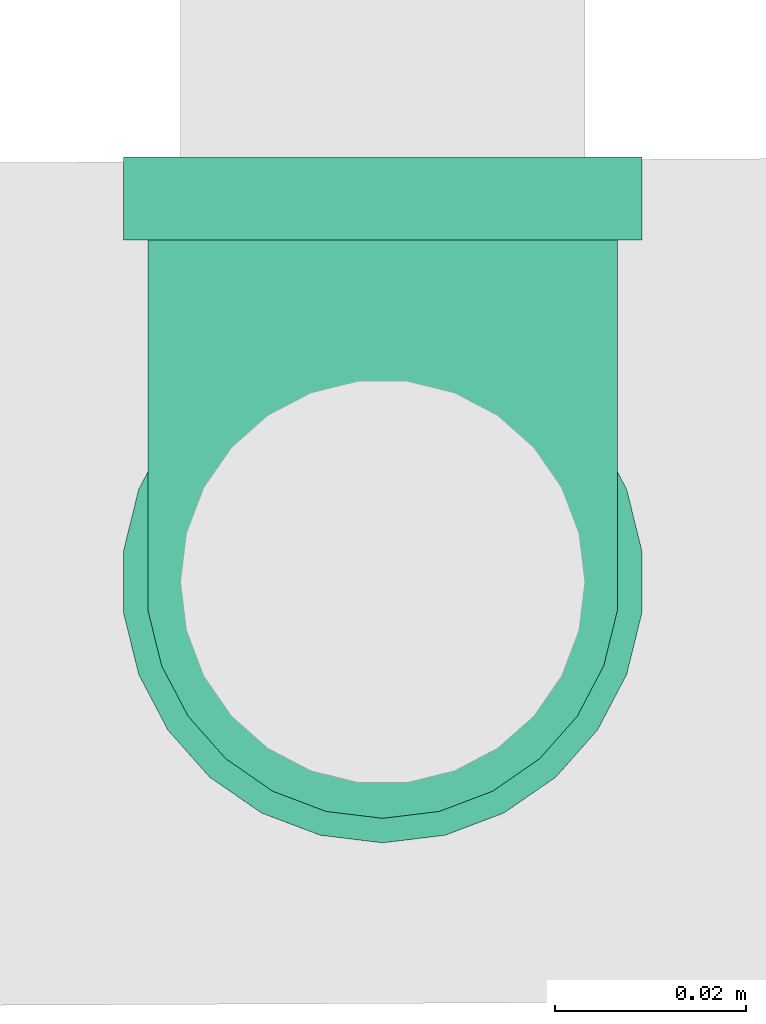
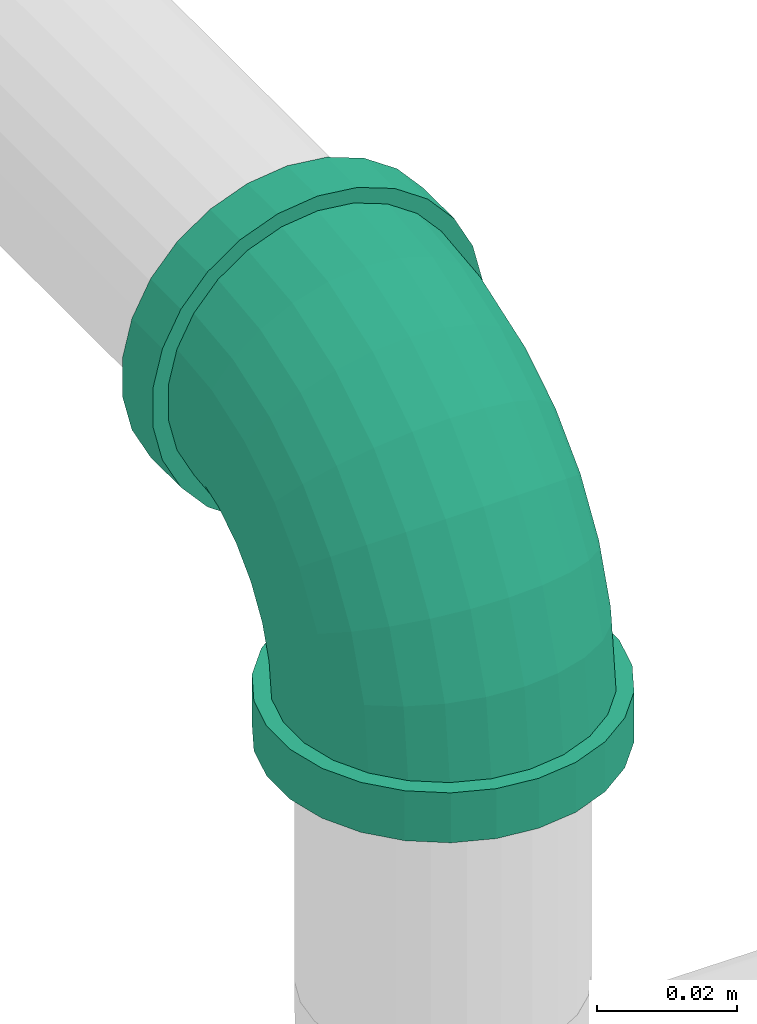
# One storey, part 3 of 7: 1 pipe fitting.
"""IFC4 building model written with IfcOpenShell, lengths in millimetres."""

from ifc_helpers import new_model, entity, si_unit, converted_unit, derived_unit, direction, frame, origin, place, context, subcontext, project, spatial, source, transform, mapped, type_object, type_shapes, element, save


model = new_model("IFC4")

# Units and contexts
model_context = context("Model", 3, precision=0.01, world=origin(), true_north=direction((6.12303176911189e-17, 1.0)))
body_context = subcontext(model_context, "Body", "Model", "MODEL_VIEW")
ifc_project = project(units=[si_unit("LENGTHUNIT", "METRE", prefix="MILLI"), si_unit("AREAUNIT", "SQUARE_METRE"), si_unit("VOLUMEUNIT", "CUBIC_METRE"), converted_unit("PLANEANGLEUNIT", "DEGREE", entity("IfcRatioMeasure", 0.0174532925199433), si_unit("PLANEANGLEUNIT", "RADIAN"), dimensions=[0, 0, 0, 0, 0, 0, 0]), si_unit("MASSUNIT", "GRAM", prefix="KILO"), derived_unit("MASSDENSITYUNIT", [(si_unit("MASSUNIT", "GRAM", prefix="KILO"), 1), (si_unit("LENGTHUNIT", "METRE"), -3)]), derived_unit("MOMENTOFINERTIAUNIT", [(si_unit("LENGTHUNIT", "METRE"), 4)]), si_unit("TIMEUNIT", "SECOND"), si_unit("FREQUENCYUNIT", "HERTZ"), si_unit("THERMODYNAMICTEMPERATUREUNIT", "DEGREE_CELSIUS"), derived_unit("THERMALTRANSMITTANCEUNIT", [(si_unit("MASSUNIT", "GRAM", prefix="KILO"), 1), (si_unit("THERMODYNAMICTEMPERATUREUNIT", "KELVIN"), -1), (si_unit("TIMEUNIT", "SECOND"), -3)]), derived_unit("VOLUMETRICFLOWRATEUNIT", [(si_unit("LENGTHUNIT", "METRE"), 3), (si_unit("TIMEUNIT", "SECOND"), -1)]), si_unit("ELECTRICCURRENTUNIT", "AMPERE"), si_unit("ELECTRICVOLTAGEUNIT", "VOLT"), si_unit("POWERUNIT", "WATT"), si_unit("FORCEUNIT", "NEWTON", prefix="KILO"), si_unit("ILLUMINANCEUNIT", "LUX"), si_unit("LUMINOUSFLUXUNIT", "LUMEN"), si_unit("LUMINOUSINTENSITYUNIT", "CANDELA"), derived_unit("USERDEFINED", [(si_unit("MASSUNIT", "GRAM", prefix="KILO"), -1), (si_unit("LENGTHUNIT", "METRE"), -2), (si_unit("TIMEUNIT", "SECOND"), 3), (si_unit("LUMINOUSFLUXUNIT", "LUMEN"), 1)]), derived_unit("LINEARVELOCITYUNIT", [(si_unit("LENGTHUNIT", "METRE"), 1), (si_unit("TIMEUNIT", "SECOND"), -1)]), si_unit("PRESSUREUNIT", "PASCAL"), derived_unit("USERDEFINED", [(si_unit("LENGTHUNIT", "METRE"), -2), (si_unit("MASSUNIT", "GRAM", prefix="KILO"), 1), (si_unit("TIMEUNIT", "SECOND"), -2)]), derived_unit("LINEARFORCEUNIT", [(si_unit("MASSUNIT", "GRAM", prefix="KILO"), 1), (si_unit("LENGTHUNIT", "METRE"), 1), (si_unit("TIMEUNIT", "SECOND"), -2), (si_unit("LENGTHUNIT", "METRE"), -1)]), derived_unit("PLANARFORCEUNIT", [(si_unit("MASSUNIT", "GRAM", prefix="KILO"), 1), (si_unit("LENGTHUNIT", "METRE"), 1), (si_unit("TIMEUNIT", "SECOND"), -2), (si_unit("LENGTHUNIT", "METRE"), -2)])], contexts=[model_context])

# Site, building, storey
site_placement = place(None, origin())
site = spatial("IfcSite", under=ifc_project, at=site_placement, CompositionType="ELEMENT")
building_placement = place(site_placement, origin())
building = spatial("IfcBuilding", under=site, at=building_placement, CompositionType="ELEMENT")
storey_placement = place(building_placement, origin())
storey = spatial("IfcBuildingStorey", under=building, at=storey_placement, Name="Ebene 1", CompositionType="ELEMENT", Elevation=0.0)

# Pipe fitting
pipe_fitting_type = type_object("IfcPipeFittingType", Name="Threaded - Elbow - MI - Class 1:Standard 4", PredefinedType="NOTDEFINED")
cartesian_point_1 = entity("IfcCartesianPoint", [-44.4999999999936, -27.3500000000084, 0.0])
vertex_point_1 = entity("IfcVertexPoint", cartesian_point_1)
cartesian_point_2 = entity("IfcCartesianPoint", [-44.4999999999936, 27.3499999999916, 0.0])
vertex_point_2 = entity("IfcVertexPoint", cartesian_point_2)
cartesian_point_3 = entity("IfcCartesianPoint", [-44.4999999999936, 0.0, 0.0])
ifc_direction_1 = entity("IfcDirection", [-1.0, 0.0, 0.0])
ifc_direction_2 = entity("IfcDirection", [0.0, 1.0, 0.0])
edge_curve_1 = entity("IfcEdgeCurve", vertex_point_1, vertex_point_2, entity("IfcTrimmedCurve", entity("IfcCircle", entity("IfcAxis2Placement3D", cartesian_point_3, ifc_direction_1, ifc_direction_2), 27.35), [cartesian_point_1], [cartesian_point_2], True, "CARTESIAN"), True)
edge_curve_2 = entity("IfcEdgeCurve", vertex_point_2, vertex_point_1, entity("IfcTrimmedCurve", entity("IfcCircle", entity("IfcAxis2Placement3D", cartesian_point_3, ifc_direction_1, ifc_direction_2), 27.35), [cartesian_point_2], [cartesian_point_1], True, "CARTESIAN"), True)
cartesian_point_4 = entity("IfcCartesianPoint", [-44.4999999999936, 21.0819999999918, 0.0])
vertex_point_3 = entity("IfcVertexPoint", cartesian_point_4)
cartesian_point_5 = entity("IfcCartesianPoint", [-44.4999999999936, -21.0820000000082, 0.0])
vertex_point_4 = entity("IfcVertexPoint", cartesian_point_5)
ifc_direction_3 = entity("IfcDirection", [1.0, 0.0, 0.0])
edge_curve_3 = entity("IfcEdgeCurve", vertex_point_3, vertex_point_4, entity("IfcTrimmedCurve", entity("IfcCircle", entity("IfcAxis2Placement3D", cartesian_point_3, ifc_direction_3, ifc_direction_2), 21.082), [cartesian_point_4], [cartesian_point_5], True, "CARTESIAN"), True)
edge_curve_4 = entity("IfcEdgeCurve", vertex_point_4, vertex_point_3, entity("IfcTrimmedCurve", entity("IfcCircle", entity("IfcAxis2Placement3D", cartesian_point_3, ifc_direction_3, ifc_direction_2), 21.082), [cartesian_point_5], [cartesian_point_4], True, "CARTESIAN"), True)
ifc_direction_4 = entity("IfcDirection", [0.0, 0.0, 1.0])
cartesian_point_6 = entity("IfcCartesianPoint", [-35.7999999999934, 27.3499999999916, 0.0])
vertex_point_5 = entity("IfcVertexPoint", cartesian_point_6)
cartesian_point_7 = entity("IfcCartesianPoint", [-35.7999999999934, -27.3500000000084, 0.0])
vertex_point_6 = entity("IfcVertexPoint", cartesian_point_7)
cartesian_point_8 = entity("IfcCartesianPoint", [-35.7999999999934, 0.0, 0.0])
edge_curve_5 = entity("IfcEdgeCurve", vertex_point_5, vertex_point_6, entity("IfcTrimmedCurve", entity("IfcCircle", entity("IfcAxis2Placement3D", cartesian_point_8, ifc_direction_3, ifc_direction_2), 27.35), [cartesian_point_6], [cartesian_point_7], True, "CARTESIAN"), True)
edge_curve_6 = entity("IfcEdgeCurve", vertex_point_6, vertex_point_5, entity("IfcTrimmedCurve", entity("IfcCircle", entity("IfcAxis2Placement3D", cartesian_point_8, ifc_direction_3, ifc_direction_2), 27.35), [cartesian_point_7], [cartesian_point_6], True, "CARTESIAN"), True)
cartesian_point_9 = entity("IfcCartesianPoint", [-35.7999999999934, -24.7800000000084, 0.0])
vertex_point_7 = entity("IfcVertexPoint", cartesian_point_9)
cartesian_point_10 = entity("IfcCartesianPoint", [-35.7999999999934, 24.7799999999916, 0.0])
vertex_point_8 = entity("IfcVertexPoint", cartesian_point_10)
edge_curve_7 = entity("IfcEdgeCurve", vertex_point_7, vertex_point_8, entity("IfcTrimmedCurve", entity("IfcCircle", entity("IfcAxis2Placement3D", cartesian_point_8, ifc_direction_1, ifc_direction_2), 24.78), [cartesian_point_9], [cartesian_point_10], True, "CARTESIAN"), True)
edge_curve_8 = entity("IfcEdgeCurve", vertex_point_8, vertex_point_7, entity("IfcTrimmedCurve", entity("IfcCircle", entity("IfcAxis2Placement3D", cartesian_point_8, ifc_direction_1, ifc_direction_2), 24.78), [cartesian_point_10], [cartesian_point_9], True, "CARTESIAN"), True)
edge_curve_9 = entity("IfcEdgeCurve", vertex_point_1, vertex_point_6, entity("IfcTrimmedCurve", entity("IfcLine", cartesian_point_1, entity("IfcVector", ifc_direction_3, 304.8)), [cartesian_point_1], [cartesian_point_7], True, "CARTESIAN"), True)
edge_curve_10 = entity("IfcEdgeCurve", vertex_point_5, vertex_point_2, entity("IfcTrimmedCurve", entity("IfcLine", cartesian_point_2, entity("IfcVector", ifc_direction_1, 304.8)), [cartesian_point_6], [cartesian_point_2], True, "CARTESIAN"), True)
cartesian_point_11 = entity("IfcCartesianPoint", [-35.7999999999935, 21.0819999999918, 0.0])
vertex_point_9 = entity("IfcVertexPoint", cartesian_point_11)
edge_curve_11 = entity("IfcEdgeCurve", vertex_point_3, vertex_point_9, entity("IfcTrimmedCurve", entity("IfcLine", cartesian_point_11, entity("IfcVector", ifc_direction_3, 304.8)), [cartesian_point_4], [cartesian_point_11], True, "CARTESIAN"), True)
cartesian_point_12 = entity("IfcCartesianPoint", [-35.7999999999934, -21.0820000000082, 0.0])
vertex_point_10 = entity("IfcVertexPoint", cartesian_point_12)
edge_curve_12 = entity("IfcEdgeCurve", vertex_point_9, vertex_point_10, entity("IfcTrimmedCurve", entity("IfcCircle", entity("IfcAxis2Placement3D", cartesian_point_8, ifc_direction_3, ifc_direction_2), 21.082), [cartesian_point_11], [cartesian_point_12], True, "CARTESIAN"), True)
edge_curve_13 = entity("IfcEdgeCurve", vertex_point_10, vertex_point_4, entity("IfcTrimmedCurve", entity("IfcLine", cartesian_point_12, entity("IfcVector", ifc_direction_1, 304.8)), [cartesian_point_12], [cartesian_point_5], True, "CARTESIAN"), True)
cartesian_point_13 = entity("IfcCartesianPoint", [-27.0374999999917, 0.0, 0.0])
edge_curve_14 = entity("IfcEdgeCurve", vertex_point_10, vertex_point_9, entity("IfcTrimmedCurve", entity("IfcCircle", entity("IfcAxis2Placement3D", cartesian_point_8, ifc_direction_3, ifc_direction_2), 21.082), [cartesian_point_12], [cartesian_point_11], True, "CARTESIAN"), True)
cartesian_point_14 = entity("IfcCartesianPoint", [27.3598993756537, 35.7924350408555, 0.0])
vertex_point_11 = entity("IfcVertexPoint", cartesian_point_14)
cartesian_point_15 = entity("IfcCartesianPoint", [-27.3400985326499, 35.8075622211851, 0.0])
vertex_point_12 = entity("IfcVertexPoint", cartesian_point_15)
cartesian_point_16 = entity("IfcCartesianPoint", [0.00990042150192459, 35.7999986310203, 0.0])
edge_curve_15 = entity("IfcEdgeCurve", vertex_point_11, vertex_point_12, entity("IfcTrimmedCurve", entity("IfcCircle", entity("IfcAxis2Placement3D", cartesian_point_16, entity("IfcDirection", [-0.000276548086464422, -0.999999961760577, 0.0]), entity("IfcDirection", [-0.999999961760577, 0.000276548086464422, 0.0])), 27.35), [cartesian_point_14], [cartesian_point_15], True, "CARTESIAN"), True)
edge_curve_16 = entity("IfcEdgeCurve", vertex_point_12, vertex_point_11, entity("IfcTrimmedCurve", entity("IfcCircle", entity("IfcAxis2Placement3D", cartesian_point_16, entity("IfcDirection", [-0.000276548086464422, -0.999999961760577, 0.0]), entity("IfcDirection", [-0.999999961760577, 0.000276548086464422, 0.0])), 27.35), [cartesian_point_15], [cartesian_point_14], True, "CARTESIAN"), True)
cartesian_point_17 = entity("IfcCartesianPoint", [-24.7700986309252, 35.8068514926029, 0.0])
vertex_point_13 = entity("IfcVertexPoint", cartesian_point_17)
cartesian_point_18 = entity("IfcCartesianPoint", [24.789899473929, 35.7931457694377, 0.0])
vertex_point_14 = entity("IfcVertexPoint", cartesian_point_18)
edge_curve_17 = entity("IfcEdgeCurve", vertex_point_13, vertex_point_14, entity("IfcTrimmedCurve", entity("IfcCircle", entity("IfcAxis2Placement3D", cartesian_point_16, entity("IfcDirection", [0.000276548086462547, 0.999999961760577, 0.0]), entity("IfcDirection", [-0.999999961760577, 0.000276548086462547, 0.0])), 24.78), [cartesian_point_17], [cartesian_point_18], True, "CARTESIAN"), True)
edge_curve_18 = entity("IfcEdgeCurve", vertex_point_14, vertex_point_13, entity("IfcTrimmedCurve", entity("IfcCircle", entity("IfcAxis2Placement3D", cartesian_point_16, entity("IfcDirection", [0.000276548086462547, 0.999999961760577, 0.0]), entity("IfcDirection", [-0.999999961760577, 0.000276548086462547, 0.0])), 24.78), [cartesian_point_18], [cartesian_point_17], True, "CARTESIAN"), True)
cartesian_point_19 = entity("IfcCartesianPoint", [-27.3376925642976, 44.5075618885021, 0.0])
vertex_point_15 = entity("IfcVertexPoint", cartesian_point_19)
cartesian_point_20 = entity("IfcCartesianPoint", [27.362305344006, 44.4924347081725, 0.0])
vertex_point_16 = entity("IfcVertexPoint", cartesian_point_20)
cartesian_point_21 = entity("IfcCartesianPoint", [0.0123063898541651, 44.4999982983373, 0.0])
edge_curve_19 = entity("IfcEdgeCurve", vertex_point_15, vertex_point_16, entity("IfcTrimmedCurve", entity("IfcCircle", entity("IfcAxis2Placement3D", cartesian_point_21, entity("IfcDirection", [0.000276548086464422, 0.999999961760577, 0.0]), entity("IfcDirection", [-0.999999961760577, 0.000276548086464422, 0.0])), 27.35), [cartesian_point_19], [cartesian_point_20], True, "CARTESIAN"), True)
edge_curve_20 = entity("IfcEdgeCurve", vertex_point_16, vertex_point_15, entity("IfcTrimmedCurve", entity("IfcCircle", entity("IfcAxis2Placement3D", cartesian_point_21, entity("IfcDirection", [0.000276548086464422, 0.999999961760577, 0.0]), entity("IfcDirection", [-0.999999961760577, 0.000276548086464422, 0.0])), 27.35), [cartesian_point_20], [cartesian_point_19], True, "CARTESIAN"), True)
cartesian_point_22 = entity("IfcCartesianPoint", [0.0123063898201877, 44.4999982983373, -21.081999999986])
vertex_point_17 = entity("IfcVertexPoint", cartesian_point_22)
cartesian_point_23 = entity("IfcCartesianPoint", [0.0123063898199927, 44.4999982983373, 21.082000000014])
vertex_point_18 = entity("IfcVertexPoint", cartesian_point_23)
ifc_direction_5 = entity("IfcDirection", [0.0, 0.0, -1.0])
edge_curve_21 = entity("IfcEdgeCurve", vertex_point_17, vertex_point_18, entity("IfcTrimmedCurve", entity("IfcCircle", entity("IfcAxis2Placement3D", cartesian_point_21, entity("IfcDirection", [-0.000276548086464422, -0.999999961760577, 0.0]), ifc_direction_5), 21.082), [cartesian_point_22], [cartesian_point_23], True, "CARTESIAN"), True)
edge_curve_22 = entity("IfcEdgeCurve", vertex_point_18, vertex_point_17, entity("IfcTrimmedCurve", entity("IfcCircle", entity("IfcAxis2Placement3D", cartesian_point_21, entity("IfcDirection", [-0.000276548086464422, -0.999999961760577, 0.0]), ifc_direction_5), 21.082), [cartesian_point_23], [cartesian_point_22], True, "CARTESIAN"), True)
edge_curve_23 = entity("IfcEdgeCurve", vertex_point_11, vertex_point_16, entity("IfcTrimmedCurve", entity("IfcLine", cartesian_point_14, entity("IfcVector", entity("IfcDirection", [0.000276548086464574, 0.999999961760577, 0.0]), 304.8)), [cartesian_point_14], [cartesian_point_20], True, "CARTESIAN"), True)
edge_curve_24 = entity("IfcEdgeCurve", vertex_point_15, vertex_point_12, entity("IfcTrimmedCurve", entity("IfcLine", cartesian_point_15, entity("IfcVector", entity("IfcDirection", [-0.000276548086464574, -0.999999961760577, 0.0]), 304.8)), [cartesian_point_19], [cartesian_point_15], True, "CARTESIAN"), True)
cartesian_point_24 = entity("IfcCartesianPoint", [0.00990042146834042, 35.7999986310203, -21.081999999986])
vertex_point_19 = entity("IfcVertexPoint", cartesian_point_24)
edge_curve_25 = entity("IfcEdgeCurve", vertex_point_17, vertex_point_19, entity("IfcTrimmedCurve", entity("IfcLine", cartesian_point_24, entity("IfcVector", entity("IfcDirection", [-0.000276548086464422, -0.999999961760577, 0.0]), 304.8)), [cartesian_point_22], [cartesian_point_24], True, "CARTESIAN"), True)
cartesian_point_25 = entity("IfcCartesianPoint", [0.00990042146775222, 35.7999986310203, 21.082000000014])
vertex_point_20 = entity("IfcVertexPoint", cartesian_point_25)
edge_curve_26 = entity("IfcEdgeCurve", vertex_point_19, vertex_point_20, entity("IfcTrimmedCurve", entity("IfcCircle", entity("IfcAxis2Placement3D", cartesian_point_16, entity("IfcDirection", [-0.000276548086464422, -0.999999961760577, 0.0]), ifc_direction_5), 21.082), [cartesian_point_24], [cartesian_point_25], True, "CARTESIAN"), True)
edge_curve_27 = entity("IfcEdgeCurve", vertex_point_20, vertex_point_18, entity("IfcTrimmedCurve", entity("IfcLine", cartesian_point_25, entity("IfcVector", entity("IfcDirection", [0.000276548086464422, 0.999999961760577, 0.0]), 304.8)), [cartesian_point_25], [cartesian_point_23], True, "CARTESIAN"), True)
cartesian_point_26 = entity("IfcCartesianPoint", [0.00747716886016596, 27.0374989660914, 0.0])
edge_curve_28 = entity("IfcEdgeCurve", vertex_point_20, vertex_point_19, entity("IfcTrimmedCurve", entity("IfcCircle", entity("IfcAxis2Placement3D", cartesian_point_16, entity("IfcDirection", [-0.000276548086464422, -0.999999961760577, 0.0]), ifc_direction_5), 21.082), [cartesian_point_25], [cartesian_point_24], True, "CARTESIAN"), True)
cartesian_point_27 = entity("IfcCartesianPoint", [-35.7999999999935, 35.809901790837, 0.0])
ifc_direction_6 = entity("IfcDirection", [0.0, -1.0, 0.0])
edge_curve_29 = entity("IfcEdgeCurve", vertex_point_13, vertex_point_8, entity("IfcTrimmedCurve", entity("IfcCircle", entity("IfcAxis2Placement3D", cartesian_point_27, ifc_direction_5, ifc_direction_6), 11.0299017908454), [cartesian_point_17], [cartesian_point_10], True, "CARTESIAN"), True)
edge_curve_30 = entity("IfcEdgeCurve", vertex_point_7, vertex_point_14, entity("IfcTrimmedCurve", entity("IfcCircle", entity("IfcAxis2Placement3D", cartesian_point_27, ifc_direction_4, ifc_direction_6), 60.5899017908454), [cartesian_point_9], [cartesian_point_18], True, "CARTESIAN"), True)
cartesian_point_28 = entity("IfcCartesianPoint", [0.00990179085189292, 35.809901790837, 0.0])
cartesian_point_29 = entity("IfcCartesianPoint", [24.7899017908519, 35.809901790837, 0.0])
cartesian_point_30 = entity("IfcCartesianPoint", [-24.7700982091481, 35.809901790837, 0.0])
shared_shape = source(origin(), body_context, "Body", "AdvancedBrep", [
    entity("IfcAdvancedBrep", entity("IfcClosedShell", [entity("IfcAdvancedFace", [entity("IfcFaceOuterBound", entity("IfcEdgeLoop", [entity("IfcOrientedEdge", None, None, edge_curve_1, True), entity("IfcOrientedEdge", None, None, edge_curve_2, True)]), True), entity("IfcFaceBound", entity("IfcEdgeLoop", [entity("IfcOrientedEdge", None, None, edge_curve_3, True), entity("IfcOrientedEdge", None, None, edge_curve_4, True)]), False)], entity("IfcPlane", entity("IfcAxis2Placement3D", cartesian_point_3, ifc_direction_1, ifc_direction_4)), True), entity("IfcAdvancedFace", [entity("IfcFaceOuterBound", entity("IfcEdgeLoop", [entity("IfcOrientedEdge", None, None, edge_curve_5, True), entity("IfcOrientedEdge", None, None, edge_curve_6, True)]), True), entity("IfcFaceBound", entity("IfcEdgeLoop", [entity("IfcOrientedEdge", None, None, edge_curve_7, True), entity("IfcOrientedEdge", None, None, edge_curve_8, True)]), False)], entity("IfcPlane", entity("IfcAxis2Placement3D", cartesian_point_8, ifc_direction_3, ifc_direction_4)), True), entity("IfcAdvancedFace", [entity("IfcFaceOuterBound", entity("IfcEdgeLoop", [entity("IfcOrientedEdge", None, None, edge_curve_1, False), entity("IfcOrientedEdge", None, None, edge_curve_9, True), entity("IfcOrientedEdge", None, None, edge_curve_5, False), entity("IfcOrientedEdge", None, None, edge_curve_10, True)]), True)], entity("IfcCylindricalSurface", entity("IfcAxis2Placement3D", cartesian_point_3, ifc_direction_1, ifc_direction_2), 27.35), True), entity("IfcAdvancedFace", [entity("IfcFaceOuterBound", entity("IfcEdgeLoop", [entity("IfcOrientedEdge", None, None, edge_curve_2, False), entity("IfcOrientedEdge", None, None, edge_curve_10, False), entity("IfcOrientedEdge", None, None, edge_curve_6, False), entity("IfcOrientedEdge", None, None, edge_curve_9, False)]), True)], entity("IfcCylindricalSurface", entity("IfcAxis2Placement3D", cartesian_point_3, ifc_direction_1, ifc_direction_2), 27.35), True), entity("IfcAdvancedFace", [entity("IfcFaceOuterBound", entity("IfcEdgeLoop", [entity("IfcOrientedEdge", None, None, edge_curve_3, False), entity("IfcOrientedEdge", None, None, edge_curve_11, True), entity("IfcOrientedEdge", None, None, edge_curve_12, True), entity("IfcOrientedEdge", None, None, edge_curve_13, True)]), True)], entity("IfcCylindricalSurface", entity("IfcAxis2Placement3D", cartesian_point_13, ifc_direction_1, ifc_direction_2), 21.082), False), entity("IfcAdvancedFace", [entity("IfcFaceOuterBound", entity("IfcEdgeLoop", [entity("IfcOrientedEdge", None, None, edge_curve_4, False), entity("IfcOrientedEdge", None, None, edge_curve_13, False), entity("IfcOrientedEdge", None, None, edge_curve_14, True), entity("IfcOrientedEdge", None, None, edge_curve_11, False)]), True)], entity("IfcCylindricalSurface", entity("IfcAxis2Placement3D", cartesian_point_13, ifc_direction_1, ifc_direction_2), 21.082), False), entity("IfcAdvancedFace", [entity("IfcFaceOuterBound", entity("IfcEdgeLoop", [entity("IfcOrientedEdge", None, None, edge_curve_15, True), entity("IfcOrientedEdge", None, None, edge_curve_16, True)]), True), entity("IfcFaceBound", entity("IfcEdgeLoop", [entity("IfcOrientedEdge", None, None, edge_curve_17, True), entity("IfcOrientedEdge", None, None, edge_curve_18, True)]), False)], entity("IfcPlane", entity("IfcAxis2Placement3D", cartesian_point_16, entity("IfcDirection", [-0.000276548086464422, -0.999999961760577, 0.0]), ifc_direction_4)), True), entity("IfcAdvancedFace", [entity("IfcFaceOuterBound", entity("IfcEdgeLoop", [entity("IfcOrientedEdge", None, None, edge_curve_19, True), entity("IfcOrientedEdge", None, None, edge_curve_20, True)]), True), entity("IfcFaceBound", entity("IfcEdgeLoop", [entity("IfcOrientedEdge", None, None, edge_curve_21, True), entity("IfcOrientedEdge", None, None, edge_curve_22, True)]), False)], entity("IfcPlane", entity("IfcAxis2Placement3D", cartesian_point_21, entity("IfcDirection", [0.000276548086464422, 0.999999961760577, 0.0]), ifc_direction_4)), True), entity("IfcAdvancedFace", [entity("IfcFaceOuterBound", entity("IfcEdgeLoop", [entity("IfcOrientedEdge", None, None, edge_curve_15, False), entity("IfcOrientedEdge", None, None, edge_curve_23, True), entity("IfcOrientedEdge", None, None, edge_curve_19, False), entity("IfcOrientedEdge", None, None, edge_curve_24, True)]), True)], entity("IfcCylindricalSurface", entity("IfcAxis2Placement3D", cartesian_point_16, entity("IfcDirection", [-0.000276548086464422, -0.999999961760577, 0.0]), entity("IfcDirection", [-0.999999961760577, 0.000276548086464422, 0.0])), 27.35), True), entity("IfcAdvancedFace", [entity("IfcFaceOuterBound", entity("IfcEdgeLoop", [entity("IfcOrientedEdge", None, None, edge_curve_16, False), entity("IfcOrientedEdge", None, None, edge_curve_24, False), entity("IfcOrientedEdge", None, None, edge_curve_20, False), entity("IfcOrientedEdge", None, None, edge_curve_23, False)]), True)], entity("IfcCylindricalSurface", entity("IfcAxis2Placement3D", cartesian_point_16, entity("IfcDirection", [-0.000276548086464422, -0.999999961760577, 0.0]), entity("IfcDirection", [-0.999999961760577, 0.000276548086464422, 0.0])), 27.35), True), entity("IfcAdvancedFace", [entity("IfcFaceOuterBound", entity("IfcEdgeLoop", [entity("IfcOrientedEdge", None, None, edge_curve_21, False), entity("IfcOrientedEdge", None, None, edge_curve_25, True), entity("IfcOrientedEdge", None, None, edge_curve_26, True), entity("IfcOrientedEdge", None, None, edge_curve_27, True)]), True)], entity("IfcCylindricalSurface", entity("IfcAxis2Placement3D", cartesian_point_26, entity("IfcDirection", [0.000276548086464422, 0.999999961760577, 0.0]), ifc_direction_5), 21.082), False), entity("IfcAdvancedFace", [entity("IfcFaceOuterBound", entity("IfcEdgeLoop", [entity("IfcOrientedEdge", None, None, edge_curve_22, False), entity("IfcOrientedEdge", None, None, edge_curve_27, False), entity("IfcOrientedEdge", None, None, edge_curve_28, True), entity("IfcOrientedEdge", None, None, edge_curve_25, False)]), True)], entity("IfcCylindricalSurface", entity("IfcAxis2Placement3D", cartesian_point_26, entity("IfcDirection", [0.000276548086464422, 0.999999961760577, 0.0]), ifc_direction_5), 21.082), False), entity("IfcAdvancedFace", [entity("IfcFaceOuterBound", entity("IfcEdgeLoop", [entity("IfcOrientedEdge", None, None, edge_curve_12, False), entity("IfcOrientedEdge", None, None, edge_curve_14, False)]), True)], entity("IfcPlane", entity("IfcAxis2Placement3D", cartesian_point_8, ifc_direction_1, ifc_direction_4)), True), entity("IfcAdvancedFace", [entity("IfcFaceOuterBound", entity("IfcEdgeLoop", [entity("IfcOrientedEdge", None, None, edge_curve_26, False), entity("IfcOrientedEdge", None, None, edge_curve_28, False)]), True)], entity("IfcPlane", entity("IfcAxis2Placement3D", cartesian_point_16, entity("IfcDirection", [0.000276548086462325, 0.999999961760577, 0.0]), ifc_direction_4)), True), entity("IfcAdvancedFace", [entity("IfcFaceOuterBound", entity("IfcEdgeLoop", [entity("IfcOrientedEdge", None, None, edge_curve_29, True), entity("IfcOrientedEdge", None, None, edge_curve_7, False), entity("IfcOrientedEdge", None, None, edge_curve_30, True), entity("IfcOrientedEdge", None, None, edge_curve_17, False)]), True)], entity("IfcSurfaceOfRevolution", entity("IfcArbitraryOpenProfileDef", "CURVE", None, entity("IfcTrimmedCurve", entity("IfcCircle", entity("IfcAxis2Placement3D", cartesian_point_28, ifc_direction_6, ifc_direction_1), 24.78), [cartesian_point_29], [cartesian_point_30], True, "CARTESIAN")), None, entity("IfcAxis1Placement", cartesian_point_27, ifc_direction_4)), True), entity("IfcAdvancedFace", [entity("IfcFaceOuterBound", entity("IfcEdgeLoop", [entity("IfcOrientedEdge", None, None, edge_curve_29, False), entity("IfcOrientedEdge", None, None, edge_curve_18, False), entity("IfcOrientedEdge", None, None, edge_curve_30, False), entity("IfcOrientedEdge", None, None, edge_curve_8, False)]), True)], entity("IfcSurfaceOfRevolution", entity("IfcArbitraryOpenProfileDef", "CURVE", None, entity("IfcTrimmedCurve", entity("IfcCircle", entity("IfcAxis2Placement3D", cartesian_point_28, ifc_direction_6, ifc_direction_1), 24.78), [cartesian_point_30], [cartesian_point_29], True, "CARTESIAN")), None, entity("IfcAxis1Placement", cartesian_point_27, ifc_direction_4)), True)])),
])
type_shapes(pipe_fitting_type, [shared_shape])
pipe_fitting_placement = place(storey_placement, frame((10775.5617589312, 94908.7256204171, 3788.68090947638), z_axis=(-1.0, 0.0, 0.0), x_axis=(0.0, 0.000276548086464319, 0.999999961760577)))
element("IfcPipeFitting", 1, at=pipe_fitting_placement, inside=storey, type_object=pipe_fitting_type, Name="Threaded - Elbow - MI - Class 1:Standard 4:2563", ObjectType="Threaded - Elbow - MI - Class 1:Standard 4", PredefinedType="NOTDEFINED", context=body_context, shape_type="MappedRepresentation", body=[
    mapped(shared_shape, transform((0.0, 0.0, 0.0), scale=1.0)),
])

save(model, "model.ifc")
